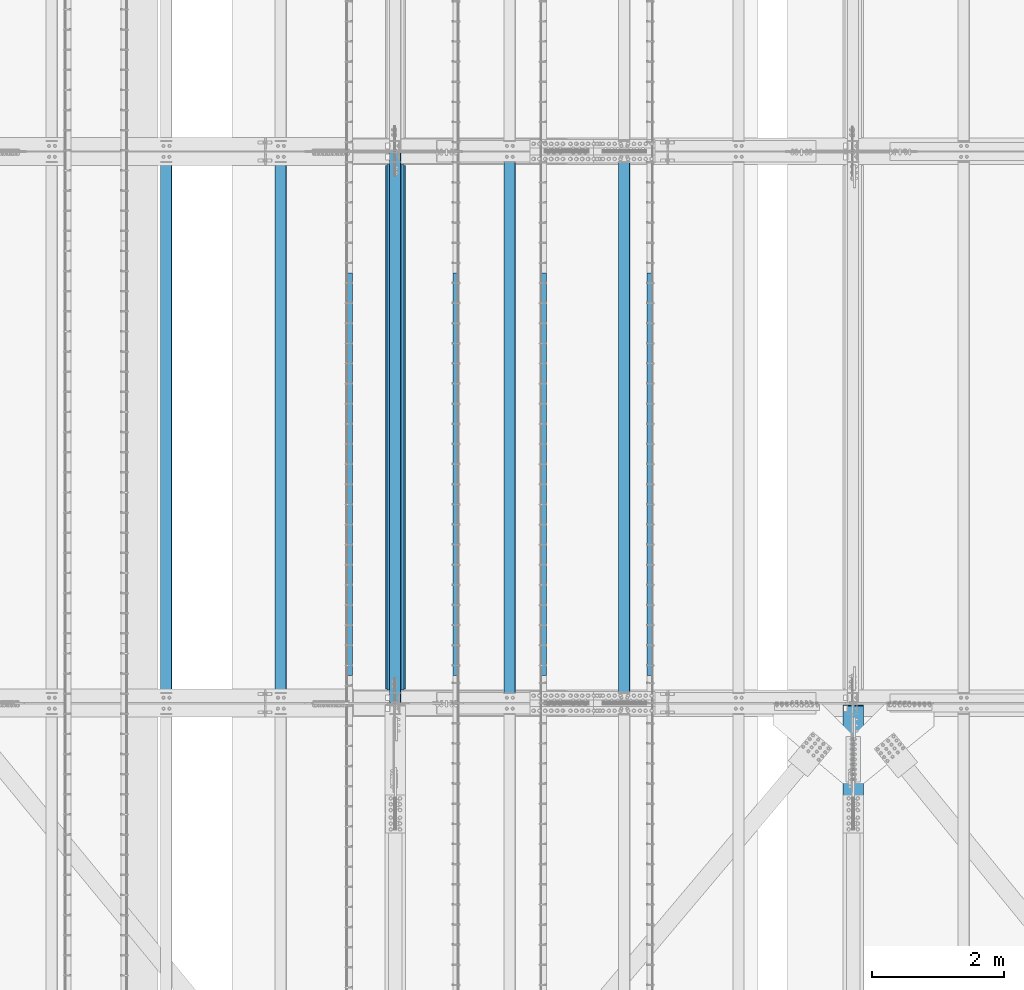
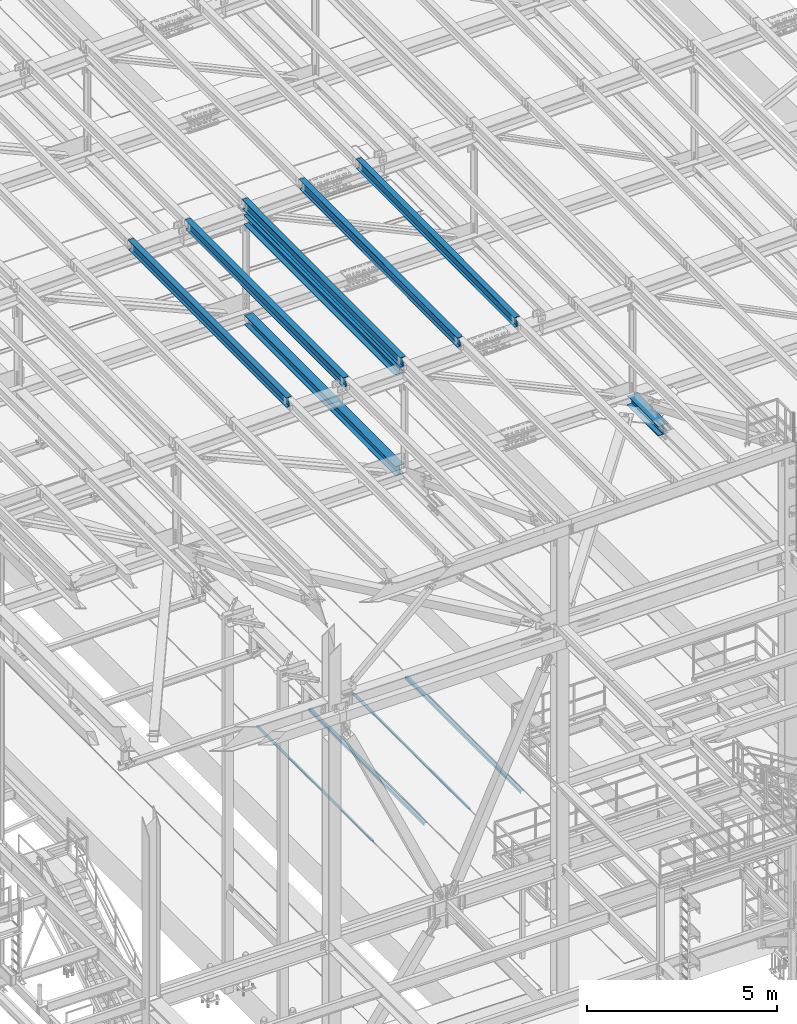
# One storey, part 1824 of 3843: 12 beams, 12 elements without a shape of their own.
"""IFC2X3 building model written with IfcOpenShell, lengths in millimetres."""

from ifc_helpers import new_model, si_unit, frame, origin_with_axes, place, context, subcontext, project, spatial, faceted_brep, material, type_object, element, aggregate, save


model = new_model("IFC2X3")

# Units and contexts
model_context = context("Model", 3, precision=1e-05, world=origin_with_axes())
body_context = subcontext(model_context, "Body", "Model", "MODEL_VIEW")
ifc_project = project(units=[si_unit("LENGTHUNIT", "METRE", prefix="MILLI"), si_unit("AREAUNIT", "SQUARE_METRE"), si_unit("VOLUMEUNIT", "CUBIC_METRE"), si_unit("MASSUNIT", "GRAM", prefix="KILO"), si_unit("TIMEUNIT", "SECOND"), si_unit("PLANEANGLEUNIT", "RADIAN"), si_unit("SOLIDANGLEUNIT", "STERADIAN"), si_unit("THERMODYNAMICTEMPERATUREUNIT", "DEGREE_CELSIUS"), si_unit("LUMINOUSINTENSITYUNIT", "LUMEN")], contexts=[model_context])

# Site, building, storey
site_placement = place(None, origin_with_axes())
site = spatial("IfcSite", under=ifc_project, at=site_placement, CompositionType="ELEMENT")
building_placement = place(site_placement, origin_with_axes())
building = spatial("IfcBuilding", under=site, at=building_placement, Name="Undefined", CompositionType="ELEMENT")
storey_placement = place(building_placement, origin_with_axes())
storey = spatial("IfcBuildingStorey", under=building, at=storey_placement, Name="Undefined", CompositionType="ELEMENT", Elevation=0.0)

# Assembly, beam
assembly_1_placement = place(storey_placement, origin_with_axes())
assembly_1 = element("IfcElementAssembly", 1, at=assembly_1_placement, inside=storey, Name="EMBED_ANGLE", AssemblyPlace="NOTDEFINED", PredefinedType="RIGID_FRAME")
ifc_material_1 = material(Name="STEEL/A36")
beam_type_1 = type_object("IfcBeamType", Name="L3-1/2X3-1/2X5/16", PredefinedType="NOTDEFINED")
beam_1_placement = place(assembly_1_placement, frame((52851.7485419922, 40360.599609375, 30410.15), z_axis=(0.0, 0.0, -1.0), x_axis=(0.0, -1.0, 0.0)))
beam_1 = element("IfcBeam", 2, at=beam_1_placement, type_object=beam_type_1, material=ifc_material_1, Name="EMBED_ANGLE", ObjectType="L3-1/2X3-1/2X5/16", context=body_context, shape_type="Brep", body=[
    faceted_brep([(-3.63797880709171e-12, 44.4499999999971, -44.4500000000007), (-3.63797880709171e-12, 44.4499999999971, 44.4500000000007), (6096.0, 44.4499999999971, 44.4500000000007), (6096.0, 44.4499999999971, -44.4500000000007), (-3.63797880709171e-12, 36.5124999999971, 44.4500000000007), (6096.0, 36.5124999999971, 44.4500000000007), (-3.63797880709171e-12, 36.5124999999971, -36.5125000000007), (6096.0, 36.5124999999971, -36.5125000000007), (3.63797880709171e-12, -44.4499999999971, -36.5125000000007), (6096.0, -44.4499999999971, -36.5125000000007), (3.63797880709171e-12, -44.4499999999971, -44.4500000000007), (6096.0, -44.4499999999971, -44.4500000000007)], [[[0, 1, 2, 3]], [[1, 4, 5, 2]], [[4, 6, 7, 5]], [[6, 8, 9, 7]], [[8, 10, 11, 9]], [[10, 0, 3, 11]], [[5, 7, 9, 11, 3, 2]], [[10, 8, 6, 4, 1, 0]]]),
])
aggregate(assembly_1, [beam_1])

assembly_2_placement = place(storey_placement, origin_with_axes())
assembly_2 = element("IfcElementAssembly", 3, at=assembly_2_placement, inside=storey, Name="EMBED_ANGLE", AssemblyPlace="NOTDEFINED", PredefinedType="RIGID_FRAME")
beam_2_placement = place(assembly_2_placement, frame((51238.911984375, 34264.599609375, 30410.15), z_axis=(0.0, 0.0, -1.0), x_axis=(0.0, 1.0, 0.0)))
beam_2 = element("IfcBeam", 4, at=beam_2_placement, type_object=beam_type_1, material=ifc_material_1, Name="EMBED_ANGLE", ObjectType="L3-1/2X3-1/2X5/16", context=body_context, shape_type="Brep", body=[
    faceted_brep([(-3.63797880709171e-12, 44.4499999999971, -44.4500000000007), (-3.63797880709171e-12, 44.4499999999971, 44.4500000000007), (6096.0, 44.4499999999971, 44.4500000000007), (6096.0, 44.4499999999971, -44.4500000000007), (-3.63797880709171e-12, 36.5124999999971, 44.4500000000007), (6096.0, 36.5124999999971, 44.4500000000007), (-3.63797880709171e-12, 36.5124999999971, -36.5125000000007), (6096.0, 36.5124999999971, -36.5125000000007), (3.63797880709171e-12, -44.4499999999971, -36.5125000000007), (6096.0, -44.4499999999971, -36.5125000000007), (3.63797880709171e-12, -44.4499999999971, -44.4500000000007), (6096.0, -44.4499999999971, -44.4500000000007)], [[[0, 1, 2, 3]], [[1, 4, 5, 2]], [[4, 6, 7, 5]], [[6, 8, 9, 7]], [[8, 10, 11, 9]], [[10, 0, 3, 11]], [[5, 7, 9, 11, 3, 2]], [[10, 8, 6, 4, 1, 0]]]),
])
aggregate(assembly_2, [beam_2])

assembly_3_placement = place(storey_placement, origin_with_axes())
assembly_3 = element("IfcElementAssembly", 5, at=assembly_3_placement, inside=storey, Name="EMBED_ANGLE", AssemblyPlace="NOTDEFINED", PredefinedType="RIGID_FRAME")
beam_3_placement = place(assembly_3_placement, frame((49911.7620576172, 40360.599609375, 30410.15), z_axis=(0.0, 0.0, -1.0), x_axis=(0.0, -1.0, 0.0)))
beam_3 = element("IfcBeam", 6, at=beam_3_placement, type_object=beam_type_1, material=ifc_material_1, Name="EMBED_ANGLE", ObjectType="L3-1/2X3-1/2X5/16", context=body_context, shape_type="Brep", body=[
    faceted_brep([(-3.63797880709171e-12, 44.4499999999971, -44.4500000000007), (-3.63797880709171e-12, 44.4499999999971, 44.4500000000007), (6096.0, 44.4499999999971, 44.4500000000007), (6096.0, 44.4499999999971, -44.4500000000007), (-3.63797880709171e-12, 36.5124999999971, 44.4500000000007), (6096.0, 36.5124999999971, 44.4500000000007), (-3.63797880709171e-12, 36.5124999999971, -36.5125000000007), (6096.0, 36.5124999999971, -36.5125000000007), (3.63797880709171e-12, -44.4499999999971, -36.5125000000007), (6096.0, -44.4499999999971, -36.5125000000007), (3.63797880709171e-12, -44.4499999999971, -44.4500000000007), (6096.0, -44.4499999999971, -44.4500000000007)], [[[0, 1, 2, 3]], [[1, 4, 5, 2]], [[4, 6, 7, 5]], [[6, 8, 9, 7]], [[8, 10, 11, 9]], [[10, 0, 3, 11]], [[5, 7, 9, 11, 3, 2]], [[10, 8, 6, 4, 1, 0]]]),
])
aggregate(assembly_3, [beam_3])

assembly_4_placement = place(storey_placement, origin_with_axes())
assembly_4 = element("IfcElementAssembly", 7, at=assembly_4_placement, inside=storey, Name="EMBED_ANGLE", AssemblyPlace="NOTDEFINED", PredefinedType="RIGID_FRAME")
beam_4_placement = place(assembly_4_placement, frame((48298.8616210938, 34264.6001953125, 30410.15), z_axis=(0.0, 0.0, -1.0), x_axis=(0.0, 1.0, 0.0)))
beam_4 = element("IfcBeam", 8, at=beam_4_placement, type_object=beam_type_1, material=ifc_material_1, Name="EMBED_ANGLE", ObjectType="L3-1/2X3-1/2X5/16", context=body_context, shape_type="Brep", body=[
    faceted_brep([(-3.63797880709171e-12, 44.4499999999971, -44.4500000000007), (-3.63797880709171e-12, 44.4499999999971, 44.4500000000007), (6096.0, 44.4499999999971, 44.4500000000007), (6096.0, 44.4499999999971, -44.4500000000007), (-3.63797880709171e-12, 36.5124999999971, 44.4500000000007), (6096.0, 36.5124999999971, 44.4500000000007), (-3.63797880709171e-12, 36.5124999999971, -36.5125000000007), (6096.0, 36.5124999999971, -36.5125000000007), (3.63797880709171e-12, -44.4499999999971, -36.5125000000007), (6096.0, -44.4499999999971, -36.5125000000007), (3.63797880709171e-12, -44.4499999999971, -44.4500000000007), (6096.0, -44.4499999999971, -44.4500000000007)], [[[0, 1, 2, 3]], [[1, 4, 5, 2]], [[4, 6, 7, 5]], [[6, 8, 9, 7]], [[8, 10, 11, 9]], [[10, 0, 3, 11]], [[5, 7, 9, 11, 3, 2]], [[10, 8, 6, 4, 1, 0]]]),
])
aggregate(assembly_4, [beam_4])

assembly_5_placement = place(storey_placement, origin_with_axes())
assembly_5 = element("IfcElementAssembly", 9, at=assembly_5_placement, inside=storey, Name="BEAM", AssemblyPlace="NOTDEFINED", PredefinedType="RIGID_FRAME")
ifc_material_2 = material(Name="STEEL/A992")
beam_type_2 = type_object("IfcBeamType", Name="W12X26", PredefinedType="NOTDEFINED")
beam_5_placement = place(assembly_5_placement, frame((48993.3092623548, 33844.6456407987, 45842.6861180875), z_axis=(-0.0211520981022549, -0.00549162299942689, 0.999761186895503), x_axis=(0.0, 0.999984914174657, 0.00549285200095969)))
beam_5 = element("IfcBeam", 10, at=beam_5_placement, type_object=beam_type_2, material=ifc_material_2, Name="BEAM", ObjectType="W12X26", context=body_context, shape_type="Brep", body=[
    faceted_brep([(12.6906062761627, 82.5500000000466, -155.575000000434), (12.7428811673817, 82.5500000000611, -146.050000000425), (8344.06859371683, 82.5499999988533, -146.049999974814), (8344.01628521782, 82.5499999988169, -155.574999974808), (12.7520975927982, 3.17499999961001, -146.050000000228), (8344.07781606766, 3.1749999990061, -146.049999974937), (14.3562584405299, 3.17500000047585, 146.049999999981), (8345.68194337067, 3.1749999999447, 146.050000024901), (14.3470360896972, 82.5500000003158, 146.050000000105), (8345.67272101984, 82.5499999997846, 146.050000025032), (14.3993445887099, 82.5500000003522, 155.575000000106), (8345.72502951885, 82.549999999821, 155.575000025026), (14.4185270784437, -82.5499999993335, 155.574999999837), (8345.74421200859, -82.5499999998647, 155.575000024764), (14.366218579431, -82.5499999993626, 146.049999999843), (8345.69190350958, -82.5499999998938, 146.05000002477), (14.3569962285983, -3.17499999951542, 146.049999999967), (8345.68268115875, -3.17500000004657, 146.050000024894), (12.7528349068307, -3.17500000042492, -146.050000000214), (8344.07855385573, -3.17500000099244, -146.049999974945), (12.7620513322399, -82.550000000876, -146.050000000017), (8344.08777620656, -82.5500000008324, -146.049999975075), (12.7097764410209, -82.5500000008906, -155.575000000019), (8344.03546770755, -82.5500000008615, -155.574999975062)], [[[0, 1, 2, 3]], [[1, 4, 5, 2]], [[4, 6, 7, 5]], [[6, 8, 9, 7]], [[8, 10, 11, 9]], [[10, 12, 13, 11]], [[12, 14, 15, 13]], [[14, 16, 17, 15]], [[16, 18, 19, 17]], [[18, 20, 21, 19]], [[20, 22, 23, 21]], [[22, 0, 3, 23]], [[5, 7, 9, 11, 13, 15, 17, 19, 21, 23, 3, 2]], [[22, 20, 18, 16, 14, 12, 10, 8, 6, 4, 1, 0]]]),
])
aggregate(assembly_5, [beam_5])

assembly_6_placement = place(storey_placement, origin_with_axes())
assembly_6 = element("IfcElementAssembly", 11, at=assembly_6_placement, inside=storey, Name="BEAM", AssemblyPlace="NOTDEFINED", PredefinedType="RIGID_FRAME")
beam_6_placement = place(assembly_6_placement, frame((52460.4092622845, 33844.4938547047, 45917.7108787534), z_axis=(-0.0211520975599923, -0.00646726799793394, 0.999755351680328), x_axis=(0.0, 0.999979077637798, 0.00646871599765735)))
beam_6 = element("IfcBeam", 12, at=beam_6_placement, type_object=beam_type_2, material=ifc_material_2, Name="BEAM", ObjectType="W12X26", context=body_context, shape_type="Brep", body=[
    faceted_brep([(12.6889703807392, 82.5499999997337, -155.574999999917), (12.7505724044604, 82.5499999997337, -146.04999999993), (8344.12488438255, 82.5499999997628, -146.050000001305), (8344.06328235883, 82.5499999997555, -155.575000001299), (12.7614332680241, 3.1749999998865, -146.049999999937), (8344.13574524611, 3.1749999999156, -146.05000000132), (14.650561995215, 3.1750000000975, 146.049999999959), (8346.02487397331, 3.1750000001266, 146.04999999857), (14.6397011316512, 82.5499999999447, 146.049999999974), (8346.01401310974, 82.5499999999738, 146.049999998591), (14.7013031553579, 82.549999999952, 155.574999999968), (8346.07561513346, 82.5499999999811, 155.574999998578), (14.7238937515795, -82.5499999997264, 155.574999999932), (8346.09820572967, -82.5499999996973, 155.574999998549), (14.6622917278582, -82.5499999997264, 146.04999999993), (8346.03660370595, -82.5499999997046, 146.049999998548), (14.6514308642945, -3.1749999998865, 146.049999999945), (8346.02574284239, -3.17499999985739, 146.04999999857), (12.7623021371037, -3.1750000000975, -146.049999999945), (8344.1366141152, -3.17500000006839, -146.05000000132), (12.7731630006674, -82.5499999999447, -146.049999999959), (8344.14747497876, -82.5499999999156, -146.050000001342), (12.7115609769535, -82.549999999952, -155.574999999961), (8344.08587295504, -82.5499999999229, -155.575000001343)], [[[0, 1, 2, 3]], [[1, 4, 5, 2]], [[4, 6, 7, 5]], [[6, 8, 9, 7]], [[8, 10, 11, 9]], [[10, 12, 13, 11]], [[12, 14, 15, 13]], [[14, 16, 17, 15]], [[16, 18, 19, 17]], [[18, 20, 21, 19]], [[20, 22, 23, 21]], [[22, 0, 3, 23]], [[5, 7, 9, 11, 13, 15, 17, 19, 21, 23, 3, 2]], [[22, 20, 18, 16, 14, 12, 10, 8, 6, 4, 1, 0]]]),
])
aggregate(assembly_6, [beam_6])

assembly_7_placement = place(storey_placement, origin_with_axes())
assembly_7 = element("IfcElementAssembly", 13, at=assembly_7_placement, inside=storey, Name="BEAM", AssemblyPlace="NOTDEFINED", PredefinedType="RIGID_FRAME")
beam_7_placement = place(assembly_7_placement, frame((50726.8592622852, 33844.4380750971, 45873.3685361565), z_axis=(-0.0211520979861161, -0.00682580700029211, 0.999752968042396), x_axis=(0.0, 0.999976693483607, 0.00682733400330201)))
beam_7 = element("IfcBeam", 14, at=beam_7_placement, type_object=beam_type_2, material=ifc_material_2, Name="BEAM", ObjectType="W12X26", context=body_context, shape_type="Brep", body=[
    faceted_brep([(12.6884123323835, 82.5500000002066, -155.57499999999), (12.7533918518166, 82.5499999998356, -146.050000000316), (8344.14756765353, 82.550000000374, -146.050000025723), (8344.08255033115, 82.5500000003667, -155.575000025739), (12.7648548564321, 3.17499999997381, -146.050000000374), (8344.15903065813, 3.17500000051223, -146.050000025767), (14.7587194091175, 3.17500000001019, 146.050000000316), (8346.15289521083, 3.17500000054861, 146.049999974915), (14.7472564045092, 82.5499999998574, 146.050000000359), (8346.14143220621, 82.5500000003958, 146.049999974952), (14.8122737268786, 82.5499999998647, 155.575000000383), (8346.20644952859, 82.5500000004031, 155.574999974975), (14.8361167764742, -82.5499999998356, 155.575000000274), (8346.23029257818, -82.5499999993044, 155.574999974873), (14.7710994540976, -82.5499999998356, 146.05000000025), (8346.16527525581, -82.5499999993044, 146.04999997485), (14.7596364494893, -3.17499999998108, 146.050000000309), (8346.15381225119, -3.17499999944994, 146.049999974908), (12.7657718967967, -3.17500000001746, -146.050000000381), (8344.15994769851, -3.17499999947904, -146.050000025774), (12.7772349014122, -82.5499999998719, -146.050000000425), (8344.17141070311, -82.5499999993335, -146.050000025825), (12.7121756450942, -82.5500000006723, -155.575000000368), (8344.10639338075, -82.5499999993335, -155.575000025849)], [[[0, 1, 2, 3]], [[1, 4, 5, 2]], [[4, 6, 7, 5]], [[6, 8, 9, 7]], [[8, 10, 11, 9]], [[10, 12, 13, 11]], [[12, 14, 15, 13]], [[14, 16, 17, 15]], [[16, 18, 19, 17]], [[18, 20, 21, 19]], [[20, 22, 23, 21]], [[22, 0, 3, 23]], [[5, 7, 9, 11, 13, 15, 17, 19, 21, 23, 3, 2]], [[22, 20, 18, 16, 14, 12, 10, 8, 6, 4, 1, 0]]]),
])
aggregate(assembly_7, [beam_7])

assembly_8_placement = place(storey_placement, origin_with_axes())
assembly_8 = element("IfcElementAssembly", 15, at=assembly_8_placement, inside=storey, Name="BEAM", AssemblyPlace="NOTDEFINED", PredefinedType="RIGID_FRAME")
beam_8_placement = place(assembly_8_placement, frame((47259.7592622689, 33844.7354149384, 45805.1737514095), z_axis=(-0.0211520975680761, -0.00491457500028629, 0.999764190057354), x_axis=(0.0, 0.99998791799666, 0.00491567499998337)))
beam_8 = element("IfcBeam", 16, at=beam_8_placement, type_object=beam_type_2, material=ifc_material_2, Name="BEAM", ObjectType="W12X26", context=body_context, shape_type="Brep", body=[
    faceted_brep([(12.6915700738464, 82.5499999998428, -155.575000000041), (12.7383819683528, 82.5499999998501, -146.050000000025), (8344.03904075827, 82.5499999993481, -146.04999997613), (8343.99222886376, 82.5499999993408, -155.574999976139), (12.7466352296979, 3.17499999998836, -146.050000000105), (8344.04729401961, 3.17499999948632, -146.049999976203), (14.1821999946987, 3.17499999999563, 146.050000000192), (8345.48285878461, 3.17499999949359, 146.050000024094), (14.1739467333682, 82.5499999998428, 146.050000000265), (8345.47460552328, 82.5499999993408, 146.050000024166), (14.2207586278819, 82.5499999998428, 155.575000000281), (8345.52141741779, 82.5499999993408, 155.575000024175), (14.2379254114494, -82.5499999998574, 155.575000000121), (8345.53858420136, -82.5500000003594, 155.575000024015), (14.191113516943, -82.5499999998501, 146.050000000112), (8345.49177230685, -82.5500000003594, 146.050000024014), (14.1828602556052, -3.17499999999563, 146.050000000185), (8345.48351904551, -3.17500000050495, 146.050000024086), (12.7472954906043, -3.17499999999563, -146.050000000105), (8344.04795428051, -3.17500000050495, -146.049999976218), (12.7555487519348, -82.5499999998574, -146.050000000185), (8344.05620754184, -82.5500000003594, -146.049999976291), (12.7087368574212, -82.5499999998501, -155.575000000194), (8344.00939564734, -82.5500000003594, -155.574999976307)], [[[0, 1, 2, 3]], [[1, 4, 5, 2]], [[4, 6, 7, 5]], [[6, 8, 9, 7]], [[8, 10, 11, 9]], [[10, 12, 13, 11]], [[12, 14, 15, 13]], [[14, 16, 17, 15]], [[16, 18, 19, 17]], [[18, 20, 21, 19]], [[20, 22, 23, 21]], [[22, 0, 3, 23]], [[5, 7, 9, 11, 13, 15, 17, 19, 21, 23, 3, 2]], [[22, 20, 18, 16, 14, 12, 10, 8, 6, 4, 1, 0]]]),
])
aggregate(assembly_8, [beam_8])

assembly_9_placement = place(storey_placement, origin_with_axes())
assembly_9 = element("IfcElementAssembly", 17, at=assembly_9_placement, inside=storey, Name="BEAM", AssemblyPlace="NOTDEFINED", PredefinedType="RIGID_FRAME")
beam_9_placement = place(assembly_9_placement, frame((45526.2092622842, 33844.8347517277, 45767.6613740994), z_axis=(-0.0211520984749004, -0.00427606199955335, 0.999767124896535), x_axis=(0.0, 0.999990853516694, 0.00427701799793247)))
beam_9 = element("IfcBeam", 18, at=beam_9_placement, type_object=beam_type_2, material=ifc_material_2, Name="BEAM", ObjectType="W12X26", context=body_context, shape_type="Brep", body=[
    faceted_brep([(12.6926480338007, 82.5499999993626, -155.574999999728), (12.7333778883403, 82.549999999399, -146.049999999748), (8344.00957977855, 82.5499999989042, -146.049999976552), (8343.96884992401, 82.5499999988751, -155.574999976525), (12.7405588439069, 3.17499999952997, -146.049999999537), (8344.01676073411, 3.17499999904248, -146.049999976341), (13.9896077164158, 3.17500000043947, 146.049999999617), (8345.26580960662, 3.17499999995198, 146.050000022813), (13.9824267608492, 82.5500000002867, 146.049999999399), (8345.25862865105, 82.5499999997992, 146.050000022609), (14.0231566153889, 82.5500000003231, 155.574999999371), (8345.29935850559, 82.5499999998356, 155.575000022582), (14.0380930029714, -82.5499999993772, 155.574999999808), (8345.31429489317, -82.5499999998719, 155.575000023018), (13.9973631484318, -82.5499999994136, 146.049999999836), (8345.27356503863, -82.549999999901, 146.050000023046), (13.9901821928652, -3.1749999995518, 146.049999999632), (8345.26638408306, -3.17500000003929, 146.050000022828), (12.7411333203563, -3.17500000045402, -146.049999999523), (8344.01733521056, -3.17500000094878, -146.04999997632), (12.7483142759229, -82.5500000003085, -146.049999999312), (8344.02451616612, -82.550000000796, -146.049999976109), (12.7075844213832, -82.5500000003449, -155.574999999284), (8343.98378631159, -82.5500000008324, -155.574999976088)], [[[0, 1, 2, 3]], [[1, 4, 5, 2]], [[4, 6, 7, 5]], [[6, 8, 9, 7]], [[8, 10, 11, 9]], [[10, 12, 13, 11]], [[12, 14, 15, 13]], [[14, 16, 17, 15]], [[16, 18, 19, 17]], [[18, 20, 21, 19]], [[20, 22, 23, 21]], [[22, 0, 3, 23]], [[5, 7, 9, 11, 13, 15, 17, 19, 21, 23, 3, 2]], [[22, 20, 18, 16, 14, 12, 10, 8, 6, 4, 1, 0]]]),
])
aggregate(assembly_9, [beam_9])

assembly_10_placement = place(storey_placement, origin_with_axes())
assembly_10 = element("IfcElementAssembly", 19, at=assembly_10_placement, inside=storey, Name="BEAM", AssemblyPlace="NOTDEFINED", PredefinedType="RIGID_FRAME")
beam_type_3 = type_object("IfcBeamType", Name="W12X79", PredefinedType="NOTDEFINED")
beam_10_placement = place(assembly_10_placement, frame((55930.8000000001, 32169.0999999867, 42253.9912208943), z_axis=(0.0, -0.00113550900035625, 0.999999355309447), x_axis=(0.0, 0.999999355309447, 0.00113550900035246)))
beam_10 = element("IfcBeam", 20, at=beam_10_placement, type_object=beam_type_3, material=ifc_material_2, Name="BEAM", ObjectType="W12X79", context=body_context, shape_type="Brep", body=[
    faceted_brep([(1656.73579023224, -6.34999999999854, -131.762499992707), (1669.43579023233, 6.34999999999854, -119.062499992615), (1669.43579023321, 6.34999999999854, 119.062500004628), (1656.73579023265, -6.34999999999854, 131.76250000437), (1650.3857902294, -6.34999999999854, -138.112499995579), (1650.3857902294, -153.987500000003, -138.112499995579), (1631.33579023228, -153.987500000003, -157.162499995567), (1631.33579023228, 153.987500000003, -157.162499995567), (1650.3857902294, 153.987500000003, -138.112499995579), (1650.3857902294, 6.34999999999854, -138.112499995579), (6.34999999578577, -153.987500000003, 157.162499999627), (6.34999999578577, -153.987500000003, 138.112499999675), (1650.3857902333, -153.987500000003, 138.112500003612), (1631.33579023275, -153.987500000003, 157.162500003498), (6.34999999578577, 153.987500000003, 157.162499999627), (1631.33579023275, 153.987500000003, 157.162500003498), (6.34999999578577, 153.987500000003, 138.112499999675), (1650.3857902333, 153.987500000003, 138.112500003612), (6.34999999578577, 6.34999999999854, 138.112499999675), (1650.3857902333, 6.34999999999854, 138.112500003612), (6.34999999578577, -153.987500000003, -157.162499999562), (6.34999999578577, -153.987500000003, -138.11249999961), (6.34999999578577, -6.34999999999854, -138.11249999961), (6.34999999578577, -6.34999999999854, 138.112499999675), (6.34999999578577, 6.34999999999854, -138.11249999961), (6.34999999578577, 153.987500000003, -138.11249999961), (6.34999999578577, 153.987500000003, -157.162499999562), (1650.3857902333, -6.34999999999854, 138.112500003612)], [[[0, 1, 2, 3]], [[4, 5, 6, 7, 8, 9, 1, 0]], [[10, 11, 12, 13]], [[14, 10, 13, 15]], [[16, 14, 15, 17]], [[18, 16, 17, 19]], [[20, 21, 22, 23, 11, 10, 14, 16, 18, 24, 25, 26]], [[11, 23, 27, 12]], [[19, 17, 15, 13, 12, 27, 3, 2]], [[24, 18, 19, 2, 1, 9]], [[25, 24, 9, 8]], [[26, 25, 8, 7]], [[20, 26, 7, 6]], [[21, 20, 6, 5]], [[22, 21, 5, 4]], [[27, 23, 22, 4, 0, 3]]]),
])
aggregate(assembly_10, [beam_10])

assembly_11_placement = place(storey_placement, origin_with_axes())
assembly_11 = element("IfcElementAssembly", 21, at=assembly_11_placement, inside=storey, Name="BEAM", AssemblyPlace="NOTDEFINED", PredefinedType="RIGID_FRAME")
beam_type_4 = type_object("IfcBeamType", Name="W12X65", PredefinedType="NOTDEFINED")
beam_11_placement = place(assembly_11_placement, frame((48996.6, 33845.5000000174, 45490.2406638138), z_axis=(0.0, -0.00549285200095617, 0.999984914174657), x_axis=(0.0, 0.999984914174657, 0.00549285200095969)))
beam_11 = element("IfcBeam", 22, at=beam_11_placement, type_object=beam_type_4, material=ifc_material_2, Name="BEAM", ObjectType="W12X65", context=body_context, shape_type="Brep", body=[
    faceted_brep([(211.882365855636, 152.400000000001, -153.987499999421), (211.96956619664, 152.400000000001, -138.112499999414), (8143.2392159512, 152.400000000001, -138.112499975687), (8143.1520156102, 152.400000000001, -153.987499975687), (211.96956619664, 4.76249999999709, -138.112499999414), (8143.2392159512, 4.76249999999709, -138.112499975687), (213.48685213011, 4.76249999999709, 138.112500000694), (8144.75650188467, 4.76249999999709, 138.112500024414), (213.48685213011, 152.400000000001, 138.112500000694), (8144.75650188467, 152.400000000001, 138.112500024414), (213.574052471115, 152.400000000001, 153.987500000694), (8144.84370222567, 152.400000000001, 153.987500024421), (213.574052471115, -152.400000000001, 153.987500000694), (8144.84370222567, -152.400000000001, 153.987500024421), (213.48685213011, -152.400000000001, 138.112500000694), (8144.75650188467, -152.400000000001, 138.112500024414), (213.48685213011, -4.76249999999709, 138.112500000694), (8144.75650188467, -4.76249999999709, 138.112500024414), (211.96956619664, -4.76249999999709, -138.112499999414), (8143.2392159512, -4.76249999999709, -138.112499975687), (211.96956619664, -152.400000000001, -138.112499999414), (8143.2392159512, -152.400000000001, -138.112499975687), (211.882365855636, -152.400000000001, -153.987499999421), (8143.1520156102, -152.400000000001, -153.987499975687)], [[[0, 1, 2, 3]], [[1, 4, 5, 2]], [[4, 6, 7, 5]], [[6, 8, 9, 7]], [[8, 10, 11, 9]], [[10, 12, 13, 11]], [[12, 14, 15, 13]], [[14, 16, 17, 15]], [[16, 18, 19, 17]], [[18, 20, 21, 19]], [[20, 22, 23, 21]], [[22, 0, 3, 23]], [[5, 7, 9, 11, 13, 15, 17, 19, 21, 23, 3, 2]], [[22, 20, 18, 16, 14, 12, 10, 8, 6, 4, 1, 0]]]),
])
aggregate(assembly_11, [beam_11])

assembly_12_placement = place(storey_placement, origin_with_axes())
assembly_12 = element("IfcElementAssembly", 23, at=assembly_12_placement, inside=storey, Name="BEAM", AssemblyPlace="NOTDEFINED", PredefinedType="RIGID_FRAME")
beam_type_5 = type_object("IfcBeamType", Name="W12X53", PredefinedType="NOTDEFINED")
beam_12_placement = place(assembly_12_placement, frame((48996.6, 33845.5, 42252.5468526654), z_axis=(0.0, -0.00549285200095617, 0.999984914174657), x_axis=(0.0, 0.999984914174657, 0.00549285200095969)))
beam_12 = element("IfcBeam", 24, at=beam_12_placement, type_object=beam_type_5, material=ifc_material_2, Name="BEAM", ObjectType="W12X53", context=body_context, shape_type="Brep", body=[
    faceted_brep([(197.603221766563, 127.0, -152.400000001013), (197.681716104395, 127.0, -138.112500000963), (8157.52683993103, 127.0, -138.112500020965), (8157.4483455932, 127.0, -152.400000021022), (197.681716104395, 4.76249999999709, -138.112500000963), (8157.52683993103, 4.76249999999709, -138.112500020965), (199.199273302504, 4.76249999999709, 138.112499999967), (8159.04439712914, 4.76249999999709, 138.112499979965), (199.199273302504, 127.0, 138.112499999967), (8159.04439712914, 127.0, 138.112499979965), (199.277767640335, 127.0, 152.400000000016), (8159.12289146698, 127.0, 152.399999980007), (199.277767640335, -127.0, 152.400000000016), (8159.12289146698, -127.0, 152.399999980007), (199.199273302504, -127.0, 138.112499999967), (8159.04439712914, -127.0, 138.112499979965), (199.199273302504, -4.76249999999709, 138.112499999967), (8159.04439712914, -4.76249999999709, 138.112499979965), (197.681716104395, -4.76249999999709, -138.112500000963), (8157.52683993103, -4.76249999999709, -138.112500020965), (197.681716104395, -127.0, -138.112500000963), (8157.52683993103, -127.0, -138.112500020965), (197.603221766563, -127.0, -152.400000001013), (8157.4483455932, -127.0, -152.400000021022)], [[[0, 1, 2, 3]], [[1, 4, 5, 2]], [[4, 6, 7, 5]], [[6, 8, 9, 7]], [[8, 10, 11, 9]], [[10, 12, 13, 11]], [[12, 14, 15, 13]], [[14, 16, 17, 15]], [[16, 18, 19, 17]], [[18, 20, 21, 19]], [[20, 22, 23, 21]], [[22, 0, 3, 23]], [[5, 7, 9, 11, 13, 15, 17, 19, 21, 23, 3, 2]], [[22, 20, 18, 16, 14, 12, 10, 8, 6, 4, 1, 0]]]),
])
aggregate(assembly_12, [beam_12])

save(model, "model.ifc")
